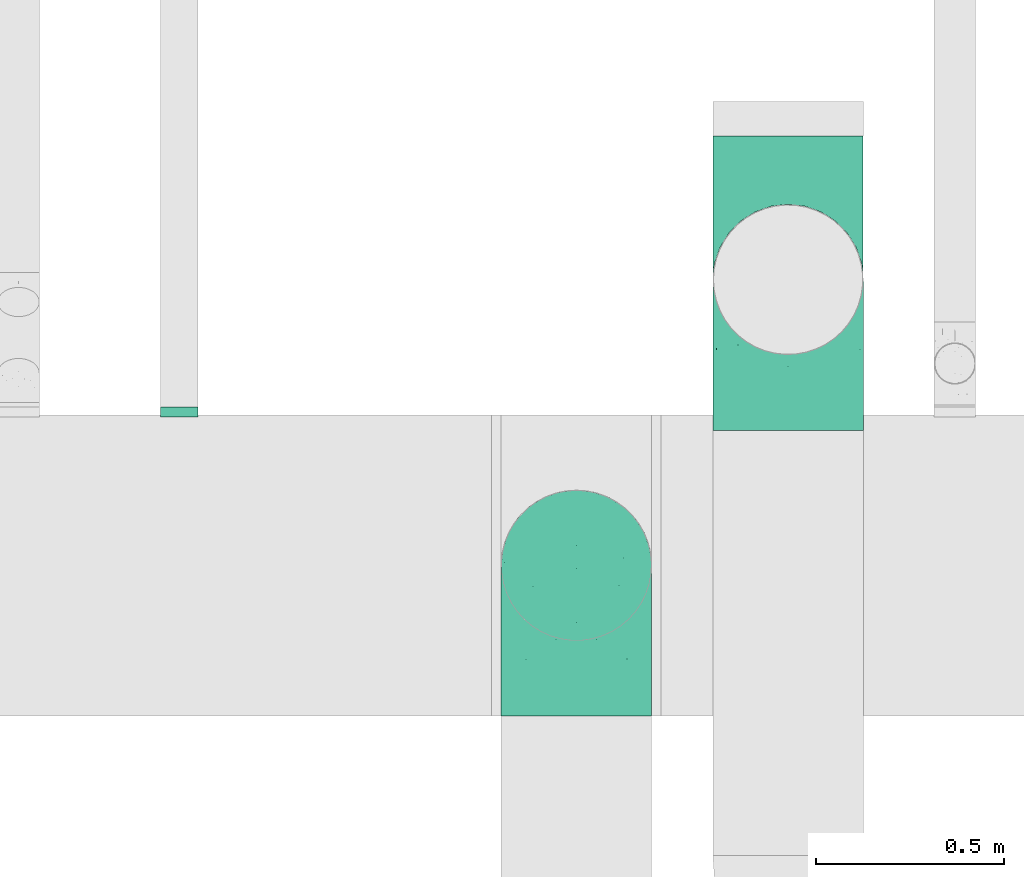
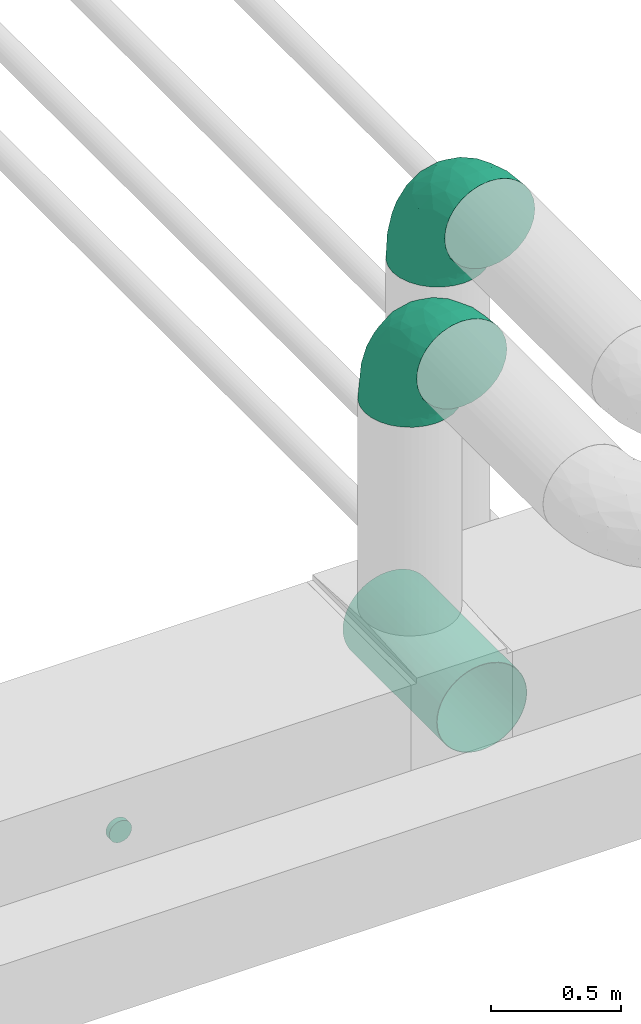
# One storey, part 34 of 91: 3 flow fittings, 1 flow segment.
"""IFC2X3 building model written with IfcOpenShell, lengths in millimetres."""

from ifc_helpers import new_model, entity, si_unit, converted_unit, derived_unit, direction, frame, origin_with_axes, origin_2d_with_axis, place, context, subcontext, project, spatial, hollow_circle, extrude, open_shell, surface_model, source, transform, mapped, material, layer, layer_set, layer_usage, type_object, element, save


model = new_model("IFC2X3")

# Units and contexts
model_context = context("Model", 3, precision=1e-05, world=origin_with_axes(), true_north=direction((0.0, 1.0)))
body_context = subcontext(model_context, "Body", "Model", "MODEL_VIEW")
ifc_project = project(units=[si_unit("AREAUNIT", "SQUARE_METRE"), si_unit("VOLUMEUNIT", "CUBIC_METRE", prefix="DECI"), si_unit("TIMEUNIT", "SECOND"), si_unit("THERMODYNAMICTEMPERATUREUNIT", "DEGREE_CELSIUS"), si_unit("PRESSUREUNIT", "PASCAL"), si_unit("MASSUNIT", "GRAM", prefix="KILO"), si_unit("LENGTHUNIT", "METRE", prefix="MILLI"), si_unit("POWERUNIT", "WATT"), si_unit("ELECTRICCURRENTUNIT", "AMPERE"), si_unit("ELECTRICVOLTAGEUNIT", "VOLT"), derived_unit("VOLUMETRICFLOWRATEUNIT", [(si_unit("VOLUMEUNIT", "CUBIC_METRE", prefix="DECI"), 1), (si_unit("TIMEUNIT", "SECOND"), -1)]), derived_unit("LINEARVELOCITYUNIT", [(si_unit("LENGTHUNIT", "METRE"), 1), (si_unit("TIMEUNIT", "SECOND"), -1)]), derived_unit("MASSDENSITYUNIT", [(si_unit("MASSUNIT", "GRAM", prefix="KILO"), 1), (si_unit("VOLUMEUNIT", "CUBIC_METRE"), -1)]), converted_unit("PLANEANGLEUNIT", "DEGREE", entity("IfcRatioMeasure", 0.01745), si_unit("PLANEANGLEUNIT", "RADIAN"), dimensions=[0, 0, 0, 0, 0, 0, 0])], contexts=[model_context])

# Site, building, storey
site_placement = place(None, origin_with_axes())
site = spatial("IfcSite", under=ifc_project, at=site_placement, CompositionType="ELEMENT")
building_placement = place(site_placement, origin_with_axes())
building = spatial("IfcBuilding", under=site, at=building_placement, Name="mc-building", CompositionType="ELEMENT")
storey_placement = place(building_placement, frame((0.0, 0.0, 8700.0), z_axis=(0.0, 0.0, 1.0), x_axis=(1.0, 0.0, 0.0)))
storey = spatial("IfcBuildingStorey", under=building, at=storey_placement, CompositionType="ELEMENT", Elevation=8700.0)

# Flow fittings
duct_fitting_type_1 = type_object("IfcDuctFittingType", Name="CC", PredefinedType="CONNECTOR")
shared_shape_1 = source(origin_with_axes(), body_context, "Body", "SurfaceModel", [
    surface_model("IfcShellBasedSurfaceModel", [(-6.096, -12.94095, -48.29629), (-6.096, -50.0, 0.0), (-6.096, 0.0, -50.0), (-6.096, -25.0, -43.30127), (-6.096, -35.35534, -35.35534), (-6.096, -43.30127, -25.0), (-6.096, 35.35534, -35.35534), (-6.096, 48.29629, 12.94095), (-6.096, 25.0, -43.30127), (-6.096, 12.94095, -48.29629), (-6.096, 43.30127, -25.0), (-6.096, 48.29629, -12.94095), (-6.096, 50.0, 0.0), (-6.096, -48.29629, -12.94095), (-6.096, -48.29629, 12.94095), (-6.096, -43.30127, 25.0), (-6.096, -35.35534, 35.35534), (-6.096, -25.0, 43.30127), (-6.096, 0.0, 50.0), (-6.096, -12.94095, 48.29629), (-6.096, 43.30127, 25.0), (-6.096, 35.35534, 35.35534), (-6.096, 25.0, 43.30127), (-6.096, 12.94095, 48.29629), (0.0, -12.94095, 48.29629), (0.0, 0.0, 50.0), (0.0, -25.0, 43.30127), (0.0, -35.35534, 35.35534), (0.0, -48.29629, 12.94095), (0.0, -43.30127, 25.0), (0.0, -50.0, 0.0), (0.0, -48.29629, -12.94095), (0.0, -43.30127, -25.0), (0.0, -35.35534, -35.35534), (0.0, -12.94095, -48.29629), (0.0, -25.0, -43.30127), (0.0, 0.0, -50.0), (0.0, 12.94095, -48.29629), (0.0, 25.0, -43.30127), (0.0, 35.35534, -35.35534), (0.0, 48.29629, -12.94095), (0.0, 43.30127, -25.0), (0.0, 50.0, 0.0), (0.0, 48.29629, 12.94095), (0.0, 43.30127, 25.0), (0.0, 35.35534, 35.35534), (0.0, 12.94095, 48.29629), (0.0, 25.0, 43.30127), (20.0, 0.0, -50.0), (20.0, 12.94095, -48.29629), (20.0, -12.94095, -48.29629), (20.0, -48.29629, 12.94095), (20.0, -25.0, -43.30127), (20.0, -43.30127, -25.0), (20.0, -35.35534, -35.35534), (20.0, 50.0, 0.0), (20.0, 48.29629, 12.94095), (20.0, 35.35534, -35.35534), (20.0, 25.0, -43.30127), (20.0, 48.29629, -12.94095), (20.0, 43.30127, -25.0), (20.0, -48.29629, -12.94095), (20.0, -43.30127, 25.0), (20.0, -35.35534, 35.35534), (20.0, -25.0, 43.30127), (20.0, 12.94095, 48.29629), (20.0, -12.94095, 48.29629), (20.0, 43.30127, 25.0), (20.0, 35.35534, 35.35534), (20.0, 25.0, 43.30127), (20.0, 0.0, 50.0), (20.0, -50.0, 0.0)], [open_shell([[[0, 1, 2]], [[3, 1, 0]], [[1, 4, 5]], [[4, 1, 3]], [[6, 2, 7]], [[2, 6, 8]], [[8, 9, 2]], [[10, 7, 11]], [[7, 10, 6]], [[11, 7, 12]], [[5, 13, 1]], [[2, 14, 15]], [[2, 15, 16]], [[17, 18, 16]], [[18, 2, 16]], [[19, 18, 17]], [[2, 20, 7]], [[21, 20, 2]], [[22, 21, 2]], [[23, 22, 2]], [[23, 2, 18]], [[2, 1, 14]], [[24, 25, 18]], [[26, 24, 19]], [[19, 24, 18]], [[16, 27, 17]], [[26, 19, 17]], [[26, 17, 27]], [[28, 29, 15]], [[30, 28, 14]], [[15, 29, 16]], [[28, 15, 14]], [[30, 14, 1]], [[27, 16, 29]], [[31, 30, 1]], [[32, 31, 13]], [[13, 31, 1]], [[4, 33, 5]], [[32, 13, 5]], [[32, 5, 33]], [[34, 35, 3]], [[36, 34, 0]], [[3, 35, 4]], [[34, 3, 0]], [[36, 0, 2]], [[33, 4, 35]], [[37, 36, 2]], [[38, 37, 9]], [[9, 37, 2]], [[6, 39, 8]], [[38, 9, 8]], [[38, 8, 39]], [[40, 41, 10]], [[42, 40, 11]], [[10, 41, 6]], [[40, 10, 11]], [[42, 11, 12]], [[39, 6, 41]], [[43, 42, 12]], [[44, 43, 7]], [[7, 43, 12]], [[21, 45, 20]], [[44, 7, 20]], [[44, 20, 45]], [[46, 47, 22]], [[25, 46, 23]], [[22, 47, 21]], [[46, 22, 23]], [[25, 23, 18]], [[45, 21, 47]], [[48, 49, 50]], [[50, 51, 52]], [[53, 54, 51]], [[52, 51, 54]], [[50, 55, 56]], [[57, 55, 58]], [[49, 58, 55]], [[59, 55, 60]], [[57, 60, 55]], [[55, 50, 49]], [[53, 51, 61]], [[62, 51, 50]], [[63, 62, 50]], [[64, 50, 65]], [[64, 63, 50]], [[64, 65, 66]], [[56, 67, 50]], [[50, 67, 68]], [[50, 68, 69]], [[65, 50, 69]], [[65, 70, 66]], [[71, 61, 51]], [[66, 70, 25]], [[64, 66, 24]], [[24, 66, 25]], [[27, 63, 26]], [[64, 24, 26]], [[64, 26, 63]], [[51, 62, 29]], [[71, 51, 28]], [[29, 62, 27]], [[51, 29, 28]], [[71, 28, 30]], [[63, 27, 62]], [[61, 71, 30]], [[53, 61, 31]], [[31, 61, 30]], [[33, 54, 32]], [[53, 31, 32]], [[53, 32, 54]], [[50, 52, 35]], [[48, 50, 34]], [[35, 52, 33]], [[50, 35, 34]], [[48, 34, 36]], [[54, 33, 52]], [[49, 48, 36]], [[58, 49, 37]], [[37, 49, 36]], [[39, 57, 38]], [[58, 37, 38]], [[58, 38, 57]], [[59, 60, 41]], [[55, 59, 40]], [[41, 60, 39]], [[59, 41, 40]], [[55, 40, 42]], [[57, 39, 60]], [[56, 55, 42]], [[67, 56, 43]], [[43, 56, 42]], [[45, 68, 44]], [[67, 43, 44]], [[67, 44, 68]], [[65, 69, 47]], [[70, 65, 46]], [[47, 69, 45]], [[65, 47, 46]], [[70, 46, 25]], [[68, 45, 69]], [[50, 56, 67]], [[68, 69, 50]], [[18, 16, 17]], [[17, 19, 18]]])]),
])
flow_fitting_placement = place(storey_placement, frame((16184.13421, 8290.34565, 668.0), z_axis=(0.0, 0.0, -1.0), x_axis=(0.0, 1.0, 0.0)))
element("IfcFlowFitting", 1, at=flow_fitting_placement, inside=storey, type_object=duct_fitting_type_1, Name="CC", context=body_context, shape_type="MappedRepresentation", body=[
    mapped(shared_shape_1, transform((0.0, 0.0, 0.0), scale=1.0)),
])
duct_fitting_type_2 = type_object("IfcDuctFittingType", Name="BU", PredefinedType="BEND")
shared_shape_2 = source(origin_with_axes(), body_context, "Body", "SurfaceModel", [
    surface_model("IfcShellBasedSurfaceModel", [(-400.0, 0.0, -200.0), (-400.0, -44.50419, -194.98559), (-400.0, 44.50419, -194.98559), (-400.0, 194.98559, 44.50419), (-400.0, 86.77674, -180.19378), (-400.0, 180.19378, -86.77674), (-400.0, 156.36629, -124.69796), (-400.0, 124.69796, -156.36629), (-400.0, -200.0, 0.0), (-400.0, -180.19378, 86.77674), (-400.0, -124.69796, -156.36629), (-400.0, -86.77674, -180.19378), (-400.0, -156.36629, -124.69796), (-400.0, -180.19378, -86.77674), (-400.0, -194.98559, -44.50419), (-400.0, 194.98559, -44.50419), (-400.0, 180.19378, 86.77674), (-400.0, 156.36629, 124.69796), (-400.0, 124.69796, 156.36629), (-400.0, 86.77674, 180.19378), (-400.0, 0.0, 200.0), (-400.0, 44.50419, 194.98559), (-400.0, -156.36629, 124.69796), (-400.0, -124.69796, 156.36629), (-400.0, -194.98559, 44.50419), (-400.0, -86.77674, 180.19378), (-400.0, -44.50419, 194.98559), (-400.0, 200.0, 0.0), (-194.98559, 400.0, 44.50419), (0.0, 400.0, -200.0), (-44.50419, 400.0, -194.98559), (-86.77674, 400.0, -180.19378), (-156.36629, 400.0, -124.69796), (-180.19378, 400.0, -86.77674), (-200.0, 400.0, 0.0), (-124.69796, 400.0, -156.36629), (156.36629, 400.0, -124.69796), (194.98559, 400.0, 44.50419), (86.77674, 400.0, -180.19378), (44.50419, 400.0, -194.98559), (124.69796, 400.0, -156.36629), (180.19378, 400.0, -86.77674), (194.98559, 400.0, -44.50419), (200.0, 400.0, 0.0), (-194.98559, 400.0, -44.50419), (-180.19378, 400.0, 86.77674), (-156.36629, 400.0, 124.69796), (-86.77674, 400.0, 180.19378), (-124.69796, 400.0, 156.36629), (-44.50419, 400.0, 194.98559), (124.69796, 400.0, 156.36629), (180.19378, 400.0, 86.77674), (156.36629, 400.0, 124.69796), (44.50419, 400.0, 194.98559), (86.77674, 400.0, 180.19378), (0.0, 400.0, 200.0), (-311.04439, 68.01314, 191.91169), (-360.46844, 68.4039, 188.77667), (-352.32006, 35.77277, 197.31443), (-330.54073, 6.0769, 200.0), (-263.19195, 24.12295, 200.0), (-213.51486, 270.31924, 100.59997), (-187.15609, 311.12218, 106.40641), (-204.91231, 317.36362, 67.86963), (-200.0, 53.58984, 200.0), (-197.74345, 111.1477, 194.30767), (-247.23242, 72.38885, 196.25526), (-256.68864, 256.68864, 32.58839), (-289.82519, 224.65778, 52.75457), (-248.54408, 248.5441, 73.99336), (-243.63371, 275.30204, 0.0), (-275.30204, 243.63371, 0.0), (-142.1827, 142.1827, 196.84374), (-142.88496, 93.58222, 200.0), (-271.45089, 124.32551, 175.54833), (-220.85071, 146.63576, 178.75804), (-259.76957, 175.46191, 147.316), (-350.66929, 110.58045, 169.34484), (-340.12953, 148.44794, 141.42136), (-308.54163, 188.2521, 106.4064), (-351.09401, 194.51642, 66.05581), (-361.24445, 172.62407, 106.40641), (-360.07224, 201.09774, 33.76184), (-300.36348, 163.70814, 139.24948), (-311.87682, 130.51714, 162.58441), (-194.26672, 352.15536, 66.05581), (-199.37996, 369.83655, 33.78914), (-206.63477, 338.94363, 33.20511), (-93.58222, 142.88496, 200.0), (-53.58984, 200.0, 200.0), (-111.1477, 197.74345, 194.30767), (-317.55983, 204.17269, 69.52389), (-333.06107, 208.69956, 32.59419), (-313.22325, 219.80622, 0.0), (-355.49582, 205.01441, 0.0), (-24.12295, 263.19195, 200.0), (-6.0769, 330.54073, 200.0), (-68.56573, 311.19245, 191.74293), (-217.40303, 217.40306, 141.07295), (-260.37399, 213.70418, 109.76458), (-125.42721, 271.96463, 174.87928), (-174.99626, 268.83246, 143.26342), (-163.21769, 225.3825, 169.72807), (-72.38885, 247.23242, 196.25526), (-35.77867, 352.31316, 197.31361), (-148.14225, 341.4288, 141.42136), (-110.51136, 351.07639, 169.34484), (-172.56981, 361.56427, 106.40641), (-224.65778, 289.82519, 52.75457), (-216.74424, 312.71216, 34.40997), (-68.38951, 360.58933, 188.77667), (-205.01441, 355.49582, 0.0), (-101.81453, 306.09531, 179.9031), (-130.71004, 312.65493, 162.27954), (-160.73603, 304.83801, 140.32812), (-143.50466, 203.50273, 184.62979), (-170.45511, 170.45511, 185.25303), (-314.32991, 100.10105, 179.54827), (-231.94286, 241.59953, 106.86055), (-203.62398, 249.73912, 129.12471), (-203.18683, 188.09564, 166.50592), (-219.80622, 313.22325, 0.0), (-361.56427, 172.56981, -106.40641), (-311.12218, 187.15609, -106.4064), (-341.4288, 148.14225, -141.42136), (-369.83655, 199.37996, -33.78914), (-360.58933, 68.38951, -188.77667), (-352.31316, 35.77867, -197.31361), (-304.83801, 160.73603, -140.32812), (-268.83248, 174.99626, -143.26341), (-271.96463, 125.42721, -174.87928), (-270.31924, 213.51487, -100.59997), (-351.07639, 110.51136, -169.34484), (-312.71216, 216.74424, -34.40997), (-289.82519, 224.65778, -52.75457), (-317.36362, 204.91231, -67.86963), (-352.15536, 194.26672, -66.05581), (-68.01314, 311.04439, -191.91169), (-68.4039, 360.4684, -188.77667), (-35.77277, 352.32006, -197.31443), (-142.1827, 142.1827, -196.84374), (-111.1477, 197.74345, -194.30767), (-93.58222, 142.88496, -200.0), (-142.88496, 93.58222, -200.0), (-200.0, 53.58984, -200.0), (-197.74345, 111.1477, -194.30767), (-204.17269, 317.55983, -69.52389), (-208.69954, 333.06107, -32.5942), (-194.51642, 351.09401, -66.05581), (-217.40303, 217.40306, -141.07295), (-213.70418, 260.37401, -109.76458), (-175.46191, 259.76955, -147.316), (-256.68864, 256.68864, -32.58839), (-247.23242, 72.38885, -196.25526), (-188.2521, 308.54167, -106.40641), (-172.62407, 361.24445, -106.40641), (-225.3825, 163.21769, -169.72807), (-203.50273, 143.50466, -184.62979), (-224.65778, 289.82519, -52.75457), (-248.54408, 248.5441, -73.99336), (-263.19195, 24.12295, -200.0), (-124.32551, 271.45089, -175.54831), (-163.70814, 300.36348, -139.24948), (-130.51714, 311.87682, -162.58441), (-148.44794, 340.12953, -141.42136), (-110.58045, 350.66929, -169.34484), (-201.09774, 360.07224, -33.76184), (-338.94363, 206.63477, -33.20511), (-146.63576, 220.85071, -178.75804), (-53.58984, 200.0, -200.0), (-72.38885, 247.23242, -196.25526), (-24.12295, 263.19195, -200.0), (-330.54073, 6.0769, -200.0), (-311.19245, 68.56573, -191.74293), (-6.0769, 330.54073, -200.0), (-306.09531, 101.81453, -179.9031), (-312.65497, 130.71004, -162.27954), (-170.45511, 170.45511, -185.25303), (-100.10105, 314.32991, -179.54827), (-241.59952, 231.94287, -106.86055), (-249.73912, 203.62398, -129.1247), (-188.09562, 203.18687, -166.50592), (-184.86177, -7.68945, -190.47945), (-47.3167, 68.9898, -181.64929), (43.28019, 97.94399, -146.26158), (-89.73868, -8.19462, -165.20748), (-284.08539, -23.9259, -196.06307), (-237.5194, -91.23123, -161.91366), (-285.29972, -62.21993, -184.899), (-107.30881, 56.88415, -193.38949), (-40.67465, 138.05292, -194.94777), (-131.25683, -108.81981, -96.04201), (-173.32759, -100.47387, -132.95037), (-35.15296, -20.32579, -124.42291), (108.22035, 131.82436, -97.48026), (127.15077, 249.03547, -134.14487), (162.73774, 297.11528, -101.94821), (45.84323, 55.57656, -115.34749), (15.96955, -15.96955, -67.48698), (-7.08356, -53.44974, 0.0), (53.44974, 7.08356, 0.0), (-304.96267, -182.15098, -62.88188), (66.48451, 298.1029, -184.38073), (23.16668, 169.83785, -182.54712), (22.2395, 260.55544, -194.94777), (-314.6111, -193.89287, 0.0), (-267.95143, -157.40498, -100.64249), (-150.75099, -145.7792, 0.0), (-230.96047, -175.69578, 0.0), (-197.18453, -157.02261, -53.19126), (-79.21044, -98.23441, -53.99454), (-294.12651, -135.91456, -136.39782), (156.86435, 197.34569, -53.92463), (98.27322, 80.18275, -55.7234), (101.78843, 289.17601, -164.41149), (86.29858, 191.80922, -152.84552), (97.15018, 155.27637, -127.46493), (182.19126, 305.22832, -62.89092), (104.75212, 75.61551, 0.0), (145.7792, 150.75099, 0.0), (-75.61551, -104.75212, 0.0), (193.89287, 314.6111, 0.0), (175.69578, 230.96047, 0.0), (98.27322, 80.18275, 55.7234), (-267.95143, -157.40498, 100.64249), (-197.18453, -157.02261, 53.19126), (-131.25683, -108.81981, 96.04201), (-304.96267, -182.15098, 62.88188), (108.22035, 131.82436, 97.48026), (156.86435, 197.34569, 53.92463), (162.73774, 297.11528, 101.94821), (-79.21044, -98.23441, 53.99454), (93.17167, 148.03003, 127.83594), (127.15077, 249.03547, 134.14487), (86.29858, 191.80922, 152.84552), (15.96955, -15.96955, 67.48698), (-173.32759, -100.47387, 132.95037), (-237.5194, -91.23123, 161.91366), (-294.12651, -135.91456, 136.39782), (-284.08539, -23.9259, 196.06307), (182.19126, 305.22832, 62.89092), (23.16668, 169.83785, 182.54712), (101.78843, 289.17601, 164.41149), (66.48451, 298.1029, 184.38073), (-107.30881, 56.88415, 193.38949), (-285.29972, -62.21993, 184.899), (-184.86177, -7.68945, 190.47945), (22.2395, 260.55544, 194.94777), (-40.67465, 138.05292, 194.94777), (-47.3167, 68.9898, 181.64929), (45.25548, 52.88294, 113.64735), (-89.73868, -8.19462, 165.20748), (43.28019, 97.94399, 146.26158), (-35.15296, -20.32579, 124.42291)], [open_shell([[[0, 1, 2]], [[2, 3, 4]], [[3, 5, 6]], [[6, 7, 3]], [[3, 7, 4]], [[2, 8, 9]], [[10, 8, 11]], [[2, 1, 11]], [[8, 12, 13]], [[13, 14, 8]], [[8, 10, 12]], [[11, 8, 2]], [[5, 3, 15]], [[2, 16, 3]], [[17, 16, 2]], [[18, 2, 19]], [[19, 2, 20]], [[2, 18, 17]], [[19, 20, 21]], [[22, 23, 9]], [[8, 24, 9]], [[25, 26, 20]], [[20, 23, 25]], [[9, 23, 20]], [[2, 9, 20]], [[27, 15, 3]], [[28, 29, 30]], [[31, 28, 30]], [[32, 33, 34]], [[34, 35, 32]], [[31, 35, 34]], [[36, 29, 37]], [[29, 38, 39]], [[29, 40, 38]], [[40, 29, 36]], [[36, 37, 41]], [[42, 41, 37]], [[42, 37, 43]], [[44, 34, 33]], [[28, 45, 29]], [[29, 45, 46]], [[47, 29, 48]], [[29, 47, 49]], [[46, 48, 29]], [[50, 29, 49]], [[51, 50, 52]], [[37, 29, 51]], [[53, 54, 49]], [[29, 50, 51]], [[49, 54, 50]], [[53, 49, 55]], [[34, 28, 31]], [[56, 57, 58]], [[20, 59, 58]], [[60, 56, 59]], [[61, 62, 63]], [[64, 65, 66]], [[67, 68, 69]], [[60, 64, 66]], [[70, 71, 67]], [[72, 65, 73]], [[74, 75, 76]], [[77, 18, 19]], [[64, 73, 65]], [[17, 18, 78]], [[79, 80, 81]], [[27, 3, 82]], [[74, 83, 84]], [[16, 17, 81]], [[85, 86, 87]], [[81, 17, 78]], [[19, 21, 57]], [[88, 89, 90]], [[80, 3, 16]], [[91, 92, 80]], [[78, 18, 77]], [[92, 93, 94]], [[95, 96, 97]], [[88, 72, 73]], [[66, 74, 56]], [[98, 99, 76]], [[71, 93, 68]], [[100, 101, 102]], [[103, 90, 89]], [[55, 49, 104]], [[28, 86, 85]], [[65, 75, 74]], [[105, 106, 48]], [[82, 80, 92]], [[90, 103, 100]], [[84, 78, 77]], [[46, 45, 107]], [[108, 109, 70]], [[46, 107, 105]], [[49, 110, 104]], [[63, 62, 85]], [[46, 105, 48]], [[45, 28, 85]], [[101, 62, 61]], [[48, 106, 47]], [[34, 111, 86]], [[70, 67, 108]], [[47, 110, 49]], [[105, 107, 62]], [[112, 106, 113]], [[114, 101, 100]], [[115, 100, 102]], [[90, 115, 72]], [[75, 65, 116]], [[89, 95, 103]], [[68, 93, 92]], [[99, 68, 79]], [[61, 108, 69]], [[63, 85, 87]], [[79, 81, 78]], [[80, 16, 81]], [[57, 77, 19]], [[117, 74, 84]], [[45, 85, 107]], [[62, 107, 85]], [[113, 106, 105]], [[106, 112, 110]], [[95, 97, 103]], [[103, 97, 112]], [[74, 66, 65]], [[56, 60, 66]], [[90, 72, 88]], [[65, 72, 116]], [[61, 118, 119]], [[113, 114, 100]], [[61, 119, 101]], [[98, 120, 102]], [[102, 101, 119]], [[115, 102, 116]], [[116, 120, 75]], [[75, 120, 76]], [[118, 98, 119]], [[84, 83, 78]], [[68, 99, 69]], [[79, 76, 99]], [[102, 120, 116]], [[76, 120, 98]], [[106, 110, 47]], [[104, 97, 96]], [[97, 104, 110]], [[55, 104, 96]], [[58, 57, 21]], [[57, 56, 117]], [[20, 58, 21]], [[56, 58, 59]], [[117, 84, 77]], [[83, 74, 76]], [[76, 79, 83]], [[79, 78, 83]], [[57, 117, 77]], [[74, 117, 56]], [[113, 105, 114]], [[112, 113, 100]], [[105, 62, 114]], [[62, 101, 114]], [[103, 112, 100]], [[112, 97, 110]], [[68, 67, 71]], [[108, 67, 69]], [[82, 92, 94]], [[80, 79, 91]], [[79, 68, 91]], [[68, 92, 91]], [[27, 82, 94]], [[3, 80, 82]], [[34, 86, 28]], [[87, 86, 111]], [[111, 121, 87]], [[109, 87, 121]], [[109, 63, 87]], [[61, 63, 108]], [[61, 69, 118]], [[102, 119, 98]], [[69, 99, 118]], [[98, 118, 99]], [[72, 115, 116]], [[100, 115, 90]], [[70, 109, 121]], [[63, 109, 108]], [[122, 123, 124]], [[125, 27, 94]], [[2, 126, 127]], [[128, 129, 130]], [[131, 129, 123]], [[7, 132, 4]], [[6, 124, 7]], [[133, 71, 134]], [[131, 123, 135]], [[136, 135, 123]], [[137, 138, 139]], [[140, 141, 142]], [[122, 6, 5]], [[143, 144, 145]], [[2, 127, 0]], [[146, 147, 148]], [[124, 132, 7]], [[149, 150, 151]], [[71, 70, 152]], [[145, 144, 153]], [[154, 148, 155]], [[153, 130, 145]], [[4, 126, 2]], [[130, 129, 156]], [[6, 122, 124]], [[140, 145, 157]], [[152, 158, 159]], [[144, 160, 153]], [[71, 152, 134]], [[161, 162, 163]], [[33, 148, 44]], [[155, 32, 164]], [[165, 35, 31]], [[44, 166, 34]], [[5, 15, 136]], [[32, 35, 164]], [[15, 125, 136]], [[33, 32, 155]], [[136, 125, 167]], [[165, 164, 35]], [[141, 168, 161]], [[142, 141, 169]], [[166, 148, 147]], [[170, 169, 141]], [[161, 168, 151]], [[147, 121, 111]], [[170, 171, 169]], [[160, 172, 173]], [[29, 174, 139]], [[70, 121, 158]], [[163, 164, 165]], [[171, 137, 174]], [[138, 31, 30]], [[175, 132, 176]], [[168, 141, 177]], [[142, 143, 140]], [[170, 161, 137]], [[157, 130, 156]], [[158, 121, 147]], [[150, 158, 154]], [[131, 134, 159]], [[135, 136, 167]], [[154, 155, 164]], [[148, 33, 155]], [[138, 165, 31]], [[178, 161, 163]], [[5, 136, 122]], [[123, 122, 136]], [[176, 132, 124]], [[132, 175, 126]], [[160, 173, 153]], [[153, 173, 175]], [[161, 170, 141]], [[137, 171, 170]], [[145, 140, 143]], [[141, 140, 177]], [[131, 179, 180]], [[176, 128, 130]], [[131, 180, 129]], [[149, 181, 156]], [[156, 129, 180]], [[157, 156, 177]], [[177, 181, 168]], [[168, 181, 151]], [[179, 149, 180]], [[163, 162, 164]], [[158, 150, 159]], [[154, 151, 150]], [[156, 181, 177]], [[151, 181, 149]], [[132, 126, 4]], [[127, 173, 172]], [[173, 127, 126]], [[0, 127, 172]], [[139, 138, 30]], [[138, 137, 178]], [[29, 139, 30]], [[137, 139, 174]], [[178, 163, 165]], [[162, 161, 151]], [[151, 154, 162]], [[154, 164, 162]], [[138, 178, 165]], [[161, 178, 137]], [[176, 124, 128]], [[175, 176, 130]], [[124, 123, 128]], [[123, 129, 128]], [[153, 175, 130]], [[175, 173, 126]], [[158, 152, 70]], [[134, 152, 159]], [[166, 147, 111]], [[148, 154, 146]], [[154, 158, 146]], [[158, 147, 146]], [[34, 166, 111]], [[44, 148, 166]], [[27, 125, 15]], [[167, 125, 94]], [[94, 93, 167]], [[133, 167, 93]], [[133, 135, 167]], [[131, 135, 134]], [[131, 159, 179]], [[156, 180, 149]], [[159, 150, 179]], [[149, 179, 150]], [[140, 157, 177]], [[130, 157, 145]], [[71, 133, 93]], [[135, 133, 134]], [[160, 144, 182]], [[183, 184, 185]], [[186, 1, 0]], [[187, 11, 188]], [[0, 172, 186]], [[182, 187, 188]], [[189, 142, 190]], [[191, 192, 193]], [[182, 186, 160]], [[182, 185, 187]], [[189, 144, 143]], [[194, 195, 196]], [[197, 198, 193]], [[199, 198, 200]], [[14, 13, 201]], [[202, 203, 204]], [[205, 8, 14]], [[182, 183, 185]], [[12, 206, 13]], [[184, 183, 203]], [[207, 208, 209]], [[207, 209, 210]], [[12, 211, 206]], [[14, 201, 205]], [[210, 191, 198]], [[182, 188, 186]], [[194, 212, 213]], [[193, 198, 191]], [[206, 211, 192]], [[214, 202, 38]], [[11, 187, 10]], [[215, 214, 195]], [[204, 171, 174]], [[40, 214, 38]], [[190, 204, 203]], [[169, 204, 190]], [[195, 216, 215]], [[12, 10, 211]], [[189, 183, 182]], [[188, 11, 1]], [[36, 195, 40]], [[208, 205, 201]], [[209, 201, 206]], [[204, 29, 39]], [[192, 191, 206]], [[191, 210, 209]], [[142, 169, 190]], [[198, 197, 213]], [[215, 203, 214]], [[196, 41, 217]], [[218, 213, 219]], [[210, 199, 220]], [[221, 222, 217]], [[29, 204, 174]], [[221, 42, 43]], [[212, 217, 222]], [[183, 190, 203]], [[40, 195, 214]], [[190, 183, 189]], [[212, 222, 219]], [[36, 41, 196]], [[213, 200, 198]], [[202, 39, 38]], [[171, 204, 169]], [[209, 206, 191]], [[42, 217, 41]], [[10, 187, 211]], [[211, 187, 192]], [[187, 185, 192]], [[193, 185, 184]], [[185, 193, 192]], [[193, 184, 197]], [[221, 217, 42]], [[212, 194, 196]], [[196, 217, 212]], [[195, 36, 196]], [[206, 201, 13]], [[201, 209, 208]], [[203, 202, 214]], [[39, 202, 204]], [[199, 210, 198]], [[207, 210, 220]], [[144, 189, 182]], [[142, 189, 143]], [[219, 213, 212]], [[200, 213, 218]], [[1, 186, 188]], [[160, 186, 172]], [[216, 195, 194]], [[203, 215, 184]], [[197, 216, 194]], [[184, 215, 216]], [[216, 197, 184]], [[197, 194, 213]], [[8, 205, 24]], [[223, 200, 218]], [[224, 225, 226]], [[208, 227, 205]], [[208, 225, 227]], [[228, 229, 230]], [[207, 220, 231]], [[232, 233, 234]], [[199, 235, 231]], [[236, 237, 238]], [[239, 60, 59]], [[225, 208, 207]], [[222, 221, 240]], [[199, 200, 235]], [[241, 242, 243]], [[23, 237, 25]], [[244, 88, 73]], [[239, 245, 246]], [[235, 226, 231]], [[55, 247, 53]], [[247, 243, 53]], [[20, 26, 239]], [[241, 248, 249]], [[60, 246, 64]], [[232, 250, 228]], [[245, 26, 25]], [[239, 26, 245]], [[22, 224, 238]], [[246, 244, 64]], [[249, 246, 251]], [[226, 225, 231]], [[24, 227, 9]], [[229, 240, 230]], [[233, 52, 50]], [[229, 219, 222]], [[22, 238, 23]], [[250, 223, 228]], [[229, 223, 219]], [[221, 43, 37]], [[250, 235, 223]], [[234, 241, 252]], [[240, 37, 51]], [[249, 248, 244]], [[221, 37, 240]], [[9, 224, 22]], [[51, 230, 240]], [[89, 88, 248]], [[244, 246, 249]], [[233, 242, 234]], [[247, 95, 89]], [[224, 9, 227]], [[242, 50, 54]], [[237, 246, 245]], [[96, 95, 247]], [[55, 96, 247]], [[247, 89, 248]], [[236, 253, 251]], [[249, 252, 241]], [[25, 237, 245]], [[241, 247, 248]], [[50, 242, 233]], [[236, 238, 224]], [[243, 242, 54]], [[229, 228, 223]], [[252, 249, 251]], [[246, 237, 251]], [[236, 224, 226]], [[237, 23, 238]], [[253, 236, 226]], [[251, 237, 236]], [[235, 253, 226]], [[251, 253, 252]], [[51, 52, 230]], [[240, 229, 222]], [[52, 233, 230]], [[228, 230, 233]], [[205, 227, 24]], [[224, 227, 225]], [[53, 243, 54]], [[241, 243, 247]], [[207, 231, 225]], [[199, 231, 220]], [[88, 244, 248]], [[64, 244, 73]], [[200, 223, 235]], [[219, 223, 218]], [[60, 239, 246]], [[239, 59, 20]], [[241, 234, 242]], [[232, 234, 252]], [[250, 252, 253]], [[233, 232, 228]], [[252, 250, 232]], [[235, 250, 253]]])]),
])
for number, where, z_axis, x_axis, name in (
    (2, (17238.01748, 7890.34565, 2971.08071), (1.0, 0.0, 0.0), (0.0, 0.0, 1.0), "BU"),
    (3, (17800.0, 8648.99645, 2971.08071), (-1.0, 0.0, 0.0), (0.0, 1.0, 0.0), "BU"),
):
    element("IfcFlowFitting", number, at=place(storey_placement, frame(where, z_axis=z_axis, x_axis=x_axis)), inside=storey, type_object=duct_fitting_type_2, Name=name, context=body_context, shape_type="MappedRepresentation", body=[
        mapped(shared_shape_2, transform((0.0, 0.0, 0.0), scale=1.0)),
    ])

# Flow segment
ifc_material = material(Name="FZ1")
ifc_layer = layer(ifc_material, 0.0)
ifc_layer_set = layer_set([ifc_layer], Name="FZ1")
ifc_layer_usage = layer_usage(ifc_layer_set, "AXIS1", "POSITIVE", 0.0)
duct_segment_type = type_object("IfcDuctSegmentType", Name="Safe", PredefinedType="RIGIDSEGMENT")
shared_shape_3 = source(origin_with_axes(), body_context, "Body", "SweptSolid", [
    extrude(hollow_circle(Radius=200.0, WallThickness=2.0, at=origin_2d_with_axis()), frame((0.0, 0.0, 0.0), z_axis=(1.0, 0.0, 0.0), x_axis=(0.0, 1.0, 0.0)), (0.0, 0.0, 1.0), 720.0),
])
flow_segment_placement = place(storey_placement, frame((17800.0, 8310.34565, 668.0), z_axis=(0.0, 0.0, 1.0), x_axis=(0.0, 1.0, 0.0)))
element("IfcFlowSegment", 4, at=flow_segment_placement, inside=storey, type_object=duct_segment_type, material=ifc_layer_usage, Name="Safe", context=body_context, shape_type="MappedRepresentation", body=[
    mapped(shared_shape_3, transform((0.0, 0.0, 0.0), scale=1.0)),
])

save(model, "model.ifc")
